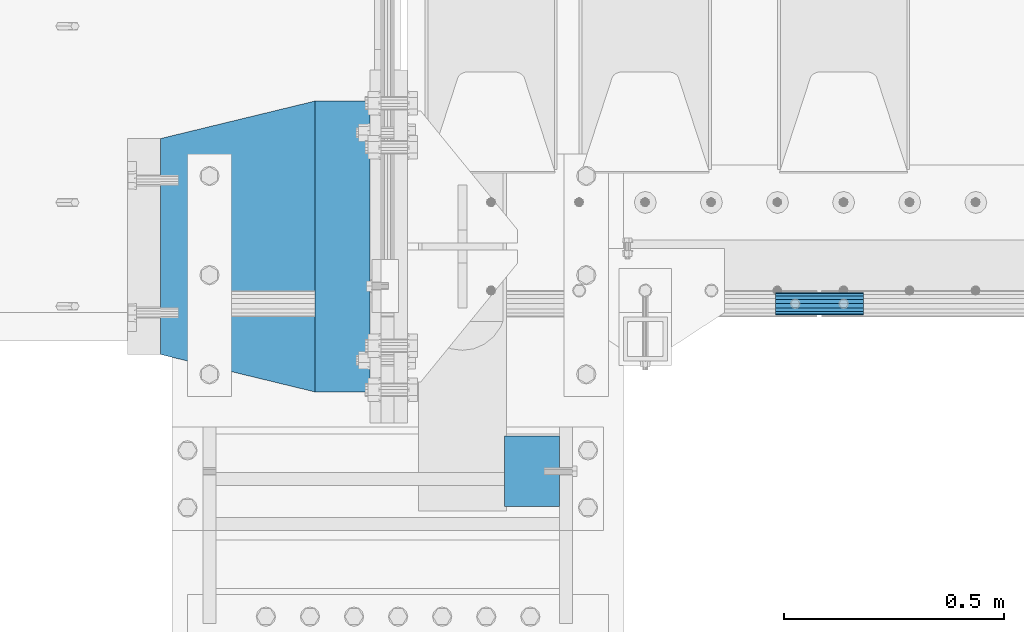
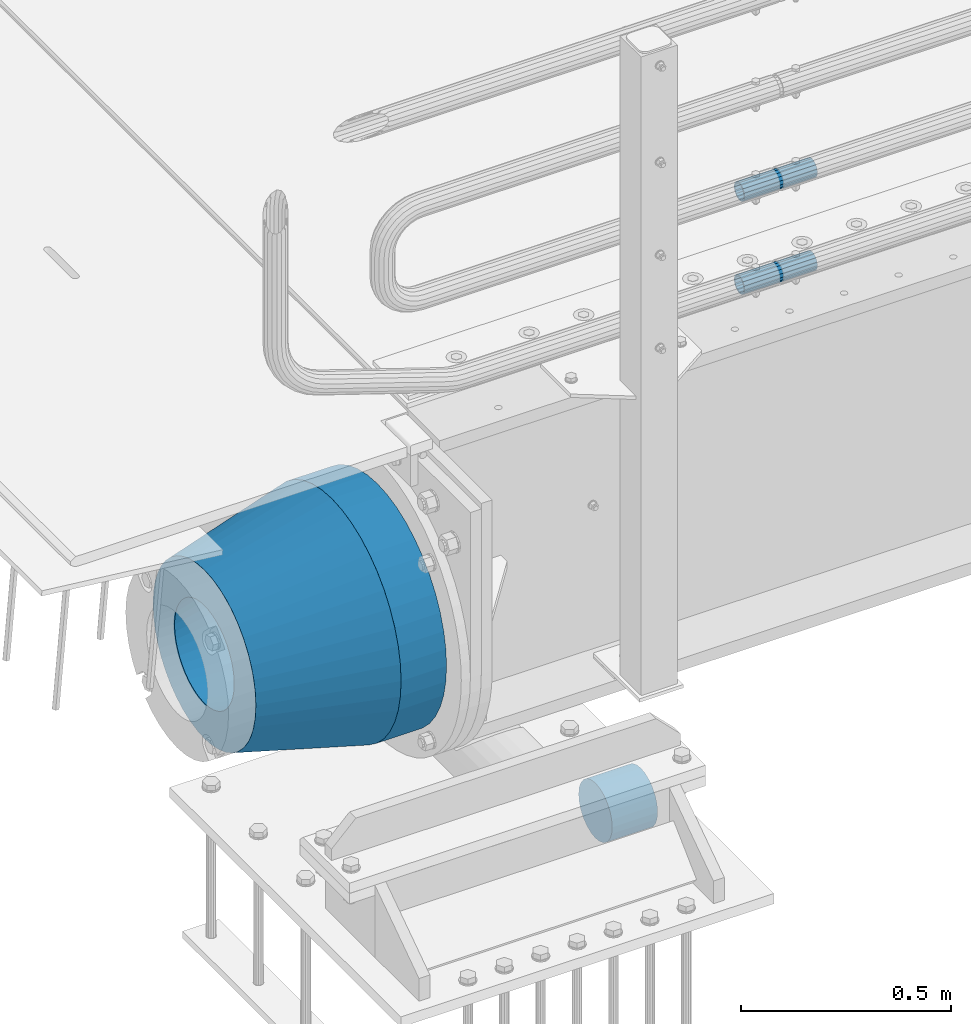
# One storey, part 151 of 270: 5 beams.
"""IFC2X3 building model written with IfcOpenShell, lengths in millimetres."""

from ifc_helpers import new_model, si_unit, frame, origin_with_axes, place, context, subcontext, project, spatial, faceted_brep, material, type_object, element, save


model = new_model("IFC2X3")

# Units and contexts
model_context = context("Model", 3, precision=1e-05, world=origin_with_axes())
body_context = subcontext(model_context, "Body", "Model", "MODEL_VIEW")
ifc_project = project(units=[si_unit("LENGTHUNIT", "METRE", prefix="MILLI"), si_unit("AREAUNIT", "SQUARE_METRE"), si_unit("VOLUMEUNIT", "CUBIC_METRE"), si_unit("MASSUNIT", "GRAM", prefix="KILO"), si_unit("TIMEUNIT", "SECOND"), si_unit("PLANEANGLEUNIT", "RADIAN"), si_unit("SOLIDANGLEUNIT", "STERADIAN"), si_unit("THERMODYNAMICTEMPERATUREUNIT", "DEGREE_CELSIUS"), si_unit("LUMINOUSINTENSITYUNIT", "LUMEN")], contexts=[model_context])

# Site, building, storey
site_placement = place(None, origin_with_axes())
site = spatial("IfcSite", under=ifc_project, at=site_placement, CompositionType="ELEMENT")
building_placement = place(site_placement, origin_with_axes())
building = spatial("IfcBuilding", under=site, at=building_placement, Name="Standard", CompositionType="ELEMENT")
storey_placement = place(building_placement, origin_with_axes())
storey = spatial("IfcBuildingStorey", under=building, at=storey_placement, Name="Undefined", CompositionType="ELEMENT", Elevation=0.0)

# Beams
ifc_material_1 = material()
beam_type_1 = type_object("IfcBeamType", PredefinedType="NOTDEFINED")
beam_1_placement = place(storey_placement, frame((230.000001139999, -24510.000002262, -933.000000000004), z_axis=(0.0, 0.0, -1.0), x_axis=(1.0, 0.0, 0.0)))
element("IfcBeam", 1, at=beam_1_placement, inside=storey, type_object=beam_type_1, material=ifc_material_1, context=body_context, shape_type="Brep", body=[
    faceted_brep([(0.0, -80.0, 0.0), (2.8421709430404e-14, -77.2740661031257, -20.7055236082017), (125.0, -77.2740661031257, -20.7055236082017), (125.0, -80.0, 0.0), (0.0, -69.2820323027554, -40.0), (125.0, -69.2820323027554, -40.0), (0.0, -56.5685424949243, -56.5685424949238), (125.0, -56.5685424949243, -56.5685424949238), (0.0, -40.0, -69.2820323027552), (125.0, -40.0, -69.2820323027552), (2.8421709430404e-14, -20.7055236082015, -77.2740661031255), (125.0, -20.7055236082015, -77.2740661031255), (0.0, 0.0, -80.0), (125.0, 0.0, -80.0), (0.0, 20.7055236082015, -77.2740661031255), (125.0, 20.7055236082015, -77.2740661031255), (0.0, 40.0, -69.2820323027551), (125.0, 40.0, -69.2820323027551), (0.0, 56.5685424949243, -56.5685424949238), (125.0, 56.5685424949243, -56.5685424949238), (0.0, 69.2820323027554, -40.0), (125.0, 69.2820323027554, -40.0), (0.0, 77.2740661031257, -20.7055236082016), (125.0, 77.2740661031257, -20.7055236082016), (2.8421709430404e-14, 80.0, 0.0), (125.0, 80.0, 0.0), (0.0, 77.2740661031257, 20.7055236082017), (125.0, 77.2740661031257, 20.7055236082017), (0.0, 69.2820323027554, 40.0), (125.0, 69.2820323027554, 40.0), (0.0, 56.5685424949243, 56.5685424949238), (125.0, 56.5685424949243, 56.5685424949238), (0.0, 40.0, 69.2820323027551), (125.0, 40.0, 69.2820323027551), (0.0, 20.7055236082015, 77.2740661031255), (125.0, 20.7055236082015, 77.2740661031255), (0.0, 0.0, 80.0), (125.0, 0.0, 80.0), (2.8421709430404e-14, -20.7055236082015, 77.2740661031255), (125.0, -20.7055236082015, 77.2740661031255), (0.0, -40.0, 69.2820323027551), (125.0, -40.0, 69.2820323027551), (0.0, -56.5685424949243, 56.5685424949238), (125.0, -56.5685424949243, 56.5685424949238), (0.0, -69.2820323027554, 40.0), (125.0, -69.2820323027554, 40.0), (2.8421709430404e-14, -77.2740661031257, 20.7055236082017), (125.0, -77.2740661031257, 20.7055236082017)], [[[0, 1, 2, 3]], [[1, 4, 5, 2]], [[4, 6, 7, 5]], [[6, 8, 9, 7]], [[8, 10, 11, 9]], [[10, 12, 13, 11]], [[12, 14, 15, 13]], [[14, 16, 17, 15]], [[16, 18, 19, 17]], [[18, 20, 21, 19]], [[20, 22, 23, 21]], [[22, 24, 25, 23]], [[24, 26, 27, 25]], [[26, 28, 29, 27]], [[28, 30, 31, 29]], [[30, 32, 33, 31]], [[32, 34, 35, 33]], [[34, 36, 37, 35]], [[36, 38, 39, 37]], [[38, 40, 41, 39]], [[40, 42, 43, 41]], [[42, 44, 45, 43]], [[44, 46, 47, 45]], [[46, 0, 3, 47]], [[5, 7, 9, 11, 13, 15, 17, 19, 21, 23, 25, 27, 29, 31, 33, 35, 37, 39, 41, 43, 45, 47, 3, 2]], [[46, 44, 42, 40, 38, 36, 34, 32, 30, 28, 26, 24, 22, 20, 18, 16, 14, 12, 10, 8, 6, 4, 1, 0]]]),
])
ifc_material_2 = material()
beam_type_2 = type_object("IfcBeamType", PredefinedType="NOTDEFINED")
beam_2_placement = place(storey_placement, frame((844.997502999948, -24129.8499999996, 149.849999999726), z_axis=(0.0, 0.0, 1.0), x_axis=(1.0, 0.0, 0.0)))
element("IfcBeam", 2, at=beam_2_placement, inside=storey, type_object=beam_type_2, material=ifc_material_2, context=body_context, shape_type="Brep", body=[
    faceted_brep([(0.0, -21.8999999999996, 0.0), (0.0, -20.232961761998, 8.38076716879547), (200.0, -20.232961761998, 8.38076716879547), (200.0, -21.8999999999996, 0.0), (0.0, -15.4856385079856, 15.4856385079854), (200.0, -15.4856385079856, 15.4856385079854), (0.0, -8.3807671687955, 20.2329617619972), (200.0, -8.3807671687955, 20.2329617619972), (0.0, 0.0, 21.9), (200.0, 0.0, 21.9), (0.0, 8.3807671687955, 20.2329617619972), (200.0, 8.3807671687955, 20.2329617619972), (0.0, 15.4856385079856, 15.4856385079854), (200.0, 15.4856385079856, 15.4856385079854), (0.0, 20.232961761998, 8.38076716879547), (200.0, 20.232961761998, 8.38076716879547), (0.0, 21.8999999999996, 0.0), (200.0, 21.8999999999996, 0.0), (0.0, 20.232961761998, -8.38076716879547), (200.0, 20.232961761998, -8.38076716879547), (0.0, 15.4856385079856, -15.4856385079854), (200.0, 15.4856385079856, -15.4856385079854), (0.0, 8.3807671687955, -20.2329617619972), (200.0, 8.3807671687955, -20.2329617619972), (0.0, 0.0, -21.9), (200.0, 0.0, -21.9), (0.0, -8.3807671687955, -20.2329617619972), (200.0, -8.3807671687955, -20.2329617619972), (0.0, -15.4856385079856, -15.4856385079854), (200.0, -15.4856385079856, -15.4856385079854), (0.0, -20.232961761998, -8.38076716879547), (200.0, -20.232961761998, -8.38076716879547), (0.0, -25.5, 0.0), (0.0, -23.5589280790373, -9.7584275253098), (200.0, -23.5589280790373, -9.7584275253098), (200.0, -25.5, 0.0), (0.0, -18.0312229202573, -18.031222920257), (200.0, -18.0312229202573, -18.031222920257), (0.0, -9.75842752531025, -23.5589280790378), (200.0, -9.75842752531025, -23.5589280790378), (0.0, 0.0, -25.5), (200.0, 0.0, -25.5), (0.0, 9.75842752531025, -23.5589280790378), (200.0, 9.75842752531025, -23.5589280790378), (0.0, 18.0312229202573, -18.031222920257), (200.0, 18.0312229202573, -18.031222920257), (0.0, 23.5589280790373, -9.7584275253098), (200.0, 23.5589280790373, -9.7584275253098), (0.0, 25.5, 0.0), (200.0, 25.5, 0.0), (0.0, 23.5589280790373, 9.7584275253098), (200.0, 23.5589280790373, 9.7584275253098), (0.0, 18.0312229202573, 18.031222920257), (200.0, 18.0312229202573, 18.031222920257), (0.0, 9.75842752531025, 23.5589280790378), (200.0, 9.75842752531025, 23.5589280790378), (0.0, 0.0, 25.5), (200.0, 0.0, 25.5), (0.0, -9.75842752531025, 23.5589280790378), (200.0, -9.75842752531025, 23.5589280790378), (0.0, -18.0312229202573, 18.031222920257), (200.0, -18.0312229202573, 18.031222920257), (0.0, -23.5589280790373, 9.7584275253098), (200.0, -23.5589280790373, 9.7584275253098)], [[[0, 1, 2, 3]], [[1, 4, 5, 2]], [[4, 6, 7, 5]], [[6, 8, 9, 7]], [[8, 10, 11, 9]], [[10, 12, 13, 11]], [[12, 14, 15, 13]], [[14, 16, 17, 15]], [[16, 18, 19, 17]], [[18, 20, 21, 19]], [[20, 22, 23, 21]], [[22, 24, 25, 23]], [[24, 26, 27, 25]], [[26, 28, 29, 27]], [[28, 30, 31, 29]], [[30, 0, 3, 31]], [[32, 33, 34, 35]], [[33, 36, 37, 34]], [[36, 38, 39, 37]], [[38, 40, 41, 39]], [[40, 42, 43, 41]], [[42, 44, 45, 43]], [[44, 46, 47, 45]], [[46, 48, 49, 47]], [[48, 50, 51, 49]], [[50, 52, 53, 51]], [[52, 54, 55, 53]], [[54, 56, 57, 55]], [[56, 58, 59, 57]], [[58, 60, 61, 59]], [[60, 62, 63, 61]], [[62, 32, 35, 63]], [[37, 39, 41, 43, 45, 47, 49, 51, 53, 55, 57, 59, 61, 63, 35, 34], [5, 7, 9, 11, 13, 15, 17, 19, 21, 23, 25, 27, 29, 31, 3, 2]], [[62, 60, 58, 56, 54, 52, 50, 48, 46, 44, 42, 40, 38, 36, 33, 32], [30, 28, 26, 24, 22, 20, 18, 16, 14, 12, 10, 8, 6, 4, 1, 0]]]),
])
beam_3_placement = place(storey_placement, frame((844.997502999948, -24129.8499999996, 420.149999999725), z_axis=(0.0, 0.0, 1.0), x_axis=(1.0, 0.0, 0.0)))
element("IfcBeam", 3, at=beam_3_placement, inside=storey, type_object=beam_type_2, material=ifc_material_2, context=body_context, shape_type="Brep", body=[
    faceted_brep([(0.0, -21.8999999999996, 0.0), (0.0, -20.232961761998, 8.38076716879547), (200.0, -20.232961761998, 8.38076716879547), (200.0, -21.8999999999996, 0.0), (0.0, -15.4856385079856, 15.4856385079854), (200.0, -15.4856385079856, 15.4856385079854), (0.0, -8.3807671687955, 20.2329617619972), (200.0, -8.3807671687955, 20.2329617619972), (0.0, 0.0, 21.9), (200.0, 0.0, 21.9), (0.0, 8.3807671687955, 20.2329617619972), (200.0, 8.3807671687955, 20.2329617619972), (0.0, 15.4856385079856, 15.4856385079854), (200.0, 15.4856385079856, 15.4856385079854), (0.0, 20.232961761998, 8.38076716879547), (200.0, 20.232961761998, 8.38076716879547), (0.0, 21.8999999999996, 0.0), (200.0, 21.8999999999996, 0.0), (0.0, 20.232961761998, -8.38076716879547), (200.0, 20.232961761998, -8.38076716879547), (0.0, 15.4856385079856, -15.4856385079854), (200.0, 15.4856385079856, -15.4856385079854), (0.0, 8.3807671687955, -20.2329617619972), (200.0, 8.3807671687955, -20.2329617619972), (0.0, 0.0, -21.9), (200.0, 0.0, -21.9), (0.0, -8.3807671687955, -20.2329617619972), (200.0, -8.3807671687955, -20.2329617619972), (0.0, -15.4856385079856, -15.4856385079854), (200.0, -15.4856385079856, -15.4856385079854), (0.0, -20.232961761998, -8.38076716879547), (200.0, -20.232961761998, -8.38076716879547), (0.0, -25.5, 0.0), (0.0, -23.5589280790373, -9.7584275253098), (200.0, -23.5589280790373, -9.7584275253098), (200.0, -25.5, 0.0), (0.0, -18.0312229202573, -18.031222920257), (200.0, -18.0312229202573, -18.031222920257), (0.0, -9.75842752531025, -23.5589280790378), (200.0, -9.75842752531025, -23.5589280790378), (0.0, 0.0, -25.5), (200.0, 0.0, -25.5), (0.0, 9.75842752531025, -23.5589280790378), (200.0, 9.75842752531025, -23.5589280790378), (0.0, 18.0312229202573, -18.031222920257), (200.0, 18.0312229202573, -18.031222920257), (0.0, 23.5589280790373, -9.7584275253098), (200.0, 23.5589280790373, -9.7584275253098), (0.0, 25.5, 0.0), (200.0, 25.5, 0.0), (0.0, 23.5589280790373, 9.7584275253098), (200.0, 23.5589280790373, 9.7584275253098), (0.0, 18.0312229202573, 18.031222920257), (200.0, 18.0312229202573, 18.031222920257), (0.0, 9.75842752531025, 23.5589280790378), (200.0, 9.75842752531025, 23.5589280790378), (0.0, 0.0, 25.5), (200.0, 0.0, 25.5), (0.0, -9.75842752531025, 23.5589280790378), (200.0, -9.75842752531025, 23.5589280790378), (0.0, -18.0312229202573, 18.031222920257), (200.0, -18.0312229202573, 18.031222920257), (0.0, -23.5589280790373, 9.7584275253098), (200.0, -23.5589280790373, 9.7584275253098)], [[[0, 1, 2, 3]], [[1, 4, 5, 2]], [[4, 6, 7, 5]], [[6, 8, 9, 7]], [[8, 10, 11, 9]], [[10, 12, 13, 11]], [[12, 14, 15, 13]], [[14, 16, 17, 15]], [[16, 18, 19, 17]], [[18, 20, 21, 19]], [[20, 22, 23, 21]], [[22, 24, 25, 23]], [[24, 26, 27, 25]], [[26, 28, 29, 27]], [[28, 30, 31, 29]], [[30, 0, 3, 31]], [[32, 33, 34, 35]], [[33, 36, 37, 34]], [[36, 38, 39, 37]], [[38, 40, 41, 39]], [[40, 42, 43, 41]], [[42, 44, 45, 43]], [[44, 46, 47, 45]], [[46, 48, 49, 47]], [[48, 50, 51, 49]], [[50, 52, 53, 51]], [[52, 54, 55, 53]], [[54, 56, 57, 55]], [[56, 58, 59, 57]], [[58, 60, 61, 59]], [[60, 62, 63, 61]], [[62, 32, 35, 63]], [[37, 39, 41, 43, 45, 47, 49, 51, 53, 55, 57, 59, 61, 63, 35, 34], [5, 7, 9, 11, 13, 15, 17, 19, 21, 23, 25, 27, 29, 31, 3, 2]], [[62, 60, 58, 56, 54, 52, 50, 48, 46, 44, 42, 40, 38, 36, 33, 32], [30, 28, 26, 24, 22, 20, 18, 16, 14, 12, 10, 8, 6, 4, 1, 0]]]),
])
ifc_material_3 = material(Name="STEEL/S355N")
beam_type_3 = type_object("IfcBeamType", PredefinedType="NOTDEFINED")
beam_4_placement = place(storey_placement, frame((-74.999999999991, -24000.0, -515.0), z_axis=(0.0, 0.0, 1.0), x_axis=(-1.0, 0.0, 0.0)))
element("IfcBeam", 4, at=beam_4_placement, inside=storey, type_object=beam_type_3, material=ifc_material_3, context=body_context, shape_type="Brep", body=[
    faceted_brep([(0.0, -215.0, 0.0), (0.0, -212.811610004401, 30.5976902287563), (125.0, -212.811610004401, 30.5976902287563), (125.0, -215.0, 0.0), (0.0, -206.290989327117, 60.5724997209074), (125.0, -206.290989327117, 60.5724997209074), (0.0, -195.570879001221, 89.3142277954056), (125.0, -195.570879001221, 89.3142277954056), (0.0, -180.869509558705, 116.237775752953), (125.0, -180.869509558705, 116.237775752953), (0.0, -162.486158486165, 140.795057798236), (125.0, -162.486158486165, 140.795057798236), (0.0, -140.795057798236, 162.486158486165), (125.0, -140.795057798236, 162.486158486165), (0.0, -116.237775752954, 180.869509558704), (125.0, -116.237775752954, 180.869509558704), (0.0, -89.3142277954048, 195.570879001222), (125.0, -89.3142277954048, 195.570879001222), (0.0, -60.5724997209072, 206.290989327117), (125.0, -60.5724997209072, 206.290989327117), (0.0, -30.5976902287566, 212.811610004401), (125.0, -30.5976902287566, 212.811610004401), (0.0, 0.0, 215.0), (125.0, 0.0, 215.0), (0.0, 30.5976902287566, 212.811610004401), (125.0, 30.5976902287566, 212.811610004401), (0.0, 60.5724997209072, 206.290989327117), (125.0, 60.5724997209072, 206.290989327117), (0.0, 89.3142277954048, 195.570879001221), (125.0, 89.3142277954048, 195.570879001221), (0.0, 116.237775752954, 180.869509558704), (125.0, 116.237775752954, 180.869509558704), (0.0, 140.795057798236, 162.486158486165), (125.0, 140.795057798236, 162.486158486165), (0.0, 162.486158486165, 140.795057798236), (125.0, 162.486158486165, 140.795057798236), (0.0, 180.869509558705, 116.237775752953), (125.0, 180.869509558705, 116.237775752953), (0.0, 195.570879001221, 89.3142277954056), (125.0, 195.570879001221, 89.3142277954056), (0.0, 206.290989327117, 60.5724997209073), (125.0, 206.290989327117, 60.5724997209073), (0.0, 212.811610004401, 30.5976902287563), (125.0, 212.811610004401, 30.5976902287563), (0.0, 215.0, 0.0), (125.0, 215.0, 0.0), (0.0, 212.811610004401, -30.5976902287563), (125.0, 212.811610004401, -30.5976902287563), (0.0, 206.290989327117, -60.5724997209073), (125.0, 206.290989327117, -60.5724997209073), (0.0, 195.570879001221, -89.3142277954056), (125.0, 195.570879001221, -89.3142277954056), (0.0, 180.869509558705, -116.237775752954), (125.0, 180.869509558705, -116.237775752954), (0.0, 162.486158486165, -140.795057798236), (125.0, 162.486158486165, -140.795057798236), (0.0, 140.795057798236, -162.486158486166), (125.0, 140.795057798236, -162.486158486166), (0.0, 116.237775752954, -180.869509558704), (125.0, 116.237775752954, -180.869509558704), (0.0, 89.3142277954048, -195.570879001221), (125.0, 89.3142277954048, -195.570879001221), (0.0, 60.5724997209072, -206.290989327117), (125.0, 60.5724997209072, -206.290989327117), (0.0, 30.5976902287566, -212.811610004401), (125.0, 30.5976902287566, -212.811610004401), (0.0, 0.0, -215.0), (125.0, 0.0, -215.0), (0.0, -30.5976902287566, -212.811610004401), (125.0, -30.5976902287566, -212.811610004401), (0.0, -60.5724997209072, -206.290989327117), (125.0, -60.5724997209072, -206.290989327117), (0.0, -89.3142277954048, -195.570879001221), (125.0, -89.3142277954048, -195.570879001221), (0.0, -116.237775752954, -180.869509558704), (125.0, -116.237775752954, -180.869509558704), (0.0, -140.795057798236, -162.486158486166), (125.0, -140.795057798236, -162.486158486166), (0.0, -162.486158486165, -140.795057798236), (125.0, -162.486158486165, -140.795057798236), (0.0, -180.869509558705, -116.237775752953), (125.0, -180.869509558705, -116.237775752953), (0.0, -195.570879001221, -89.3142277954056), (125.0, -195.570879001221, -89.3142277954056), (0.0, -206.290989327117, -60.5724997209073), (125.0, -206.290989327117, -60.5724997209073), (0.0, -212.811610004401, -30.5976902287563), (125.0, -212.811610004401, -30.5976902287563), (0.0, -330.0, 0.0), (0.0, -326.641075820708, -46.9638966301842), (125.0, -326.641075820708, -46.9638966301842), (125.0, -330.0, 0.0), (0.0, -316.632681292784, -92.9717437576718), (125.0, -316.632681292784, -92.9717437576718), (0.0, -300.178558466991, -137.086954290623), (125.0, -300.178558466991, -137.086954290623), (0.0, -277.613665834289, -178.411469760347), (125.0, -277.613665834289, -178.411469760347), (0.0, -249.397359536906, -216.104042201944), (125.0, -249.397359536906, -216.104042201944), (0.0, -216.104042201943, -249.397359536905), (125.0, -216.104042201943, -249.397359536905), (0.0, -178.411469760347, -277.61366583429), (125.0, -178.411469760347, -277.61366583429), (0.0, -137.086954290622, -300.178558466991), (125.0, -137.086954290622, -300.178558466991), (0.0, -92.971743757671, -316.632681292784), (125.0, -92.971743757671, -316.632681292784), (0.0, -46.9638966301845, -326.641075820708), (125.0, -46.9638966301845, -326.641075820708), (0.0, 0.0, -330.0), (125.0, 0.0, -330.0), (0.0, 46.9638966301845, -326.641075820708), (125.0, 46.9638966301845, -326.641075820708), (0.0, 92.971743757671, -316.632681292784), (125.0, 92.971743757671, -316.632681292784), (0.0, 137.086954290622, -300.178558466991), (125.0, 137.086954290622, -300.178558466991), (0.0, 178.411469760347, -277.61366583429), (125.0, 178.411469760347, -277.61366583429), (0.0, 216.104042201943, -249.397359536905), (125.0, 216.104042201943, -249.397359536905), (0.0, 249.397359536906, -216.104042201944), (125.0, 249.397359536906, -216.104042201944), (0.0, 277.613665834289, -178.411469760347), (125.0, 277.613665834289, -178.411469760347), (0.0, 300.178558466991, -137.086954290623), (125.0, 300.178558466991, -137.086954290623), (0.0, 316.632681292784, -92.9717437576717), (125.0, 316.632681292784, -92.9717437576717), (0.0, 326.641075820708, -46.9638966301841), (125.0, 326.641075820708, -46.9638966301841), (0.0, 330.0, 0.0), (125.0, 330.0, 0.0), (0.0, 326.641075820708, 46.9638966301841), (125.0, 326.641075820708, 46.9638966301841), (0.0, 316.632681292784, 92.9717437576718), (125.0, 316.632681292784, 92.9717437576718), (0.0, 300.178558466991, 137.086954290622), (125.0, 300.178558466991, 137.086954290622), (0.0, 277.613665834289, 178.411469760347), (125.0, 277.613665834289, 178.411469760347), (0.0, 249.397359536904, 216.104042201944), (125.0, 249.397359536904, 216.104042201944), (0.0, 216.104042201943, 249.397359536905), (125.0, 216.104042201943, 249.397359536905), (0.0, 178.411469760347, 277.61366583429), (125.0, 178.411469760347, 277.61366583429), (0.0, 137.086954290622, 300.178558466991), (125.0, 137.086954290622, 300.178558466991), (0.0, 92.971743757671, 316.632681292784), (125.0, 92.971743757671, 316.632681292784), (0.0, 46.9638966301845, 326.641075820708), (125.0, 46.9638966301845, 326.641075820708), (0.0, 0.0, 330.0), (125.0, 0.0, 330.0), (0.0, -46.9638966301845, 326.641075820708), (125.0, -46.9638966301845, 326.641075820708), (0.0, -92.971743757671, 316.632681292784), (125.0, -92.971743757671, 316.632681292784), (0.0, -137.086954290622, 300.178558466991), (125.0, -137.086954290622, 300.178558466991), (0.0, -178.411469760347, 277.61366583429), (125.0, -178.411469760347, 277.61366583429), (0.0, -216.104042201943, 249.397359536905), (125.0, -216.104042201943, 249.397359536905), (0.0, -249.397359536906, 216.104042201944), (125.0, -249.397359536906, 216.104042201944), (0.0, -277.613665834289, 178.411469760347), (125.0, -277.613665834289, 178.411469760347), (0.0, -300.178558466991, 137.086954290623), (125.0, -300.178558466991, 137.086954290623), (0.0, -316.632681292784, 92.9717437576718), (125.0, -316.632681292784, 92.9717437576718), (0.0, -326.641075820708, 46.9638966301841), (125.0, -326.641075820708, 46.9638966301841)], [[[0, 1, 2, 3]], [[1, 4, 5, 2]], [[4, 6, 7, 5]], [[6, 8, 9, 7]], [[8, 10, 11, 9]], [[10, 12, 13, 11]], [[12, 14, 15, 13]], [[14, 16, 17, 15]], [[16, 18, 19, 17]], [[18, 20, 21, 19]], [[20, 22, 23, 21]], [[22, 24, 25, 23]], [[24, 26, 27, 25]], [[26, 28, 29, 27]], [[28, 30, 31, 29]], [[30, 32, 33, 31]], [[32, 34, 35, 33]], [[34, 36, 37, 35]], [[36, 38, 39, 37]], [[38, 40, 41, 39]], [[40, 42, 43, 41]], [[42, 44, 45, 43]], [[44, 46, 47, 45]], [[46, 48, 49, 47]], [[48, 50, 51, 49]], [[50, 52, 53, 51]], [[52, 54, 55, 53]], [[54, 56, 57, 55]], [[56, 58, 59, 57]], [[58, 60, 61, 59]], [[60, 62, 63, 61]], [[62, 64, 65, 63]], [[64, 66, 67, 65]], [[66, 68, 69, 67]], [[68, 70, 71, 69]], [[70, 72, 73, 71]], [[72, 74, 75, 73]], [[74, 76, 77, 75]], [[76, 78, 79, 77]], [[78, 80, 81, 79]], [[80, 82, 83, 81]], [[82, 84, 85, 83]], [[84, 86, 87, 85]], [[86, 0, 3, 87]], [[88, 89, 90, 91]], [[89, 92, 93, 90]], [[92, 94, 95, 93]], [[94, 96, 97, 95]], [[96, 98, 99, 97]], [[98, 100, 101, 99]], [[100, 102, 103, 101]], [[102, 104, 105, 103]], [[104, 106, 107, 105]], [[106, 108, 109, 107]], [[108, 110, 111, 109]], [[110, 112, 113, 111]], [[112, 114, 115, 113]], [[114, 116, 117, 115]], [[116, 118, 119, 117]], [[118, 120, 121, 119]], [[120, 122, 123, 121]], [[122, 124, 125, 123]], [[124, 126, 127, 125]], [[126, 128, 129, 127]], [[128, 130, 131, 129]], [[130, 132, 133, 131]], [[132, 134, 135, 133]], [[134, 136, 137, 135]], [[136, 138, 139, 137]], [[138, 140, 141, 139]], [[140, 142, 143, 141]], [[142, 144, 145, 143]], [[144, 146, 147, 145]], [[146, 148, 149, 147]], [[148, 150, 151, 149]], [[150, 152, 153, 151]], [[152, 154, 155, 153]], [[154, 156, 157, 155]], [[156, 158, 159, 157]], [[158, 160, 161, 159]], [[160, 162, 163, 161]], [[162, 164, 165, 163]], [[164, 166, 167, 165]], [[166, 168, 169, 167]], [[168, 170, 171, 169]], [[170, 172, 173, 171]], [[172, 174, 175, 173]], [[174, 88, 91, 175]], [[93, 95, 97, 99, 101, 103, 105, 107, 109, 111, 113, 115, 117, 119, 121, 123, 125, 127, 129, 131, 133, 135, 137, 139, 141, 143, 145, 147, 149, 151, 153, 155, 157, 159, 161, 163, 165, 167, 169, 171, 173, 175, 91, 90], [5, 7, 9, 11, 13, 15, 17, 19, 21, 23, 25, 27, 29, 31, 33, 35, 37, 39, 41, 43, 45, 47, 49, 51, 53, 55, 57, 59, 61, 63, 65, 67, 69, 71, 73, 75, 77, 79, 81, 83, 85, 87, 3, 2]], [[174, 172, 170, 168, 166, 164, 162, 160, 158, 156, 154, 152, 150, 148, 146, 144, 142, 140, 138, 136, 134, 132, 130, 128, 126, 124, 122, 120, 118, 116, 114, 112, 110, 108, 106, 104, 102, 100, 98, 96, 94, 92, 89, 88], [86, 84, 82, 80, 78, 76, 74, 72, 70, 68, 66, 64, 62, 60, 58, 56, 54, 52, 50, 48, 46, 44, 42, 40, 38, 36, 34, 32, 30, 28, 26, 24, 22, 20, 18, 16, 14, 12, 10, 8, 6, 4, 1, 0]]]),
])
ifc_material_4 = material(Name="SCN-500-E2")
beam_type_4 = type_object("IfcBeamType", PredefinedType="NOTDEFINED")
beam_5_placement = place(storey_placement, frame((-199.999999999991, -24000.0, -515.0), z_axis=(0.0, 0.0, 1.0), x_axis=(-1.0, 0.0, 0.0)))
element("IfcBeam", 5, at=beam_5_placement, inside=storey, type_object=beam_type_4, material=ifc_material_4, context=body_context, shape_type="Brep", body=[
    faceted_brep([(0.0, -330.0, 0.0), (0.0, -326.641075820708, -46.9638966301842), (350.0, -242.506253260828, -34.8671353769549), (350.0, -245.0, 0.0), (0.0, -316.632681292784, -92.9717437576718), (350.0, -235.075778535553, -69.0244764261503), (0.0, -300.178558466991, -137.086954290623), (350.0, -222.859838861858, -101.776678185462), (0.0, -277.613665834289, -178.411469760347), (350.0, -206.10711554364, -132.457000276621), (0.0, -249.397359536906, -216.104042201944), (350.0, -185.158645716794, -160.440879816595), (0.0, -216.104042201943, -249.397359536905), (350.0, -160.440879816595, -185.158645716793), (0.0, -178.411469760347, -277.61366583429), (350.0, -132.457000276621, -206.107115543639), (0.0, -137.086954290622, -300.178558466991), (350.0, -101.776678185463, -222.859838861857), (0.0, -92.971743757671, -316.632681292784), (350.0, -69.0244764261497, -235.075778535552), (0.0, -46.9638966301845, -326.641075820708), (350.0, -34.867135376955, -242.506253260829), (0.0, 0.0, -330.0), (350.0, 0.0, -245.0), (0.0, 46.9638966301845, -326.641075820708), (350.0, 34.867135376955, -242.506253260829), (0.0, 92.971743757671, -316.632681292784), (350.0, 69.0244764261497, -235.075778535552), (0.0, 137.086954290622, -300.178558466991), (350.0, 101.776678185463, -222.859838861857), (0.0, 178.411469760347, -277.61366583429), (350.0, 132.457000276621, -206.107115543639), (0.0, 216.104042201943, -249.397359536905), (350.0, 160.440879816595, -185.158645716793), (0.0, 249.397359536906, -216.104042201944), (350.0, 185.158645716794, -160.440879816595), (0.0, 277.613665834289, -178.411469760347), (350.0, 206.10711554364, -132.457000276621), (0.0, 300.178558466991, -137.086954290623), (350.0, 222.859838861858, -101.776678185462), (0.0, 316.632681292784, -92.9717437576717), (350.0, 235.075778535553, -69.0244764261502), (0.0, 326.641075820708, -46.9638966301841), (350.0, 242.506253260828, -34.8671353769548), (0.0, 330.0, 0.0), (350.0, 245.0, 0.0), (0.0, 326.641075820708, 46.9638966301841), (350.0, 242.506253260828, 34.8671353769549), (0.0, 316.632681292784, 92.9717437576718), (350.0, 235.075778535553, 69.0244764261503), (0.0, 300.178558466991, 137.086954290622), (350.0, 222.859838861858, 101.776678185462), (0.0, 277.613665834289, 178.411469760347), (350.0, 206.10711554364, 132.457000276621), (0.0, 249.397359536904, 216.104042201944), (350.0, 185.158645716794, 160.440879816595), (0.0, 216.104042201943, 249.397359536905), (350.0, 160.440879816595, 185.158645716793), (0.0, 178.411469760347, 277.61366583429), (350.0, 132.457000276621, 206.107115543639), (0.0, 137.086954290622, 300.178558466991), (350.0, 101.776678185463, 222.859838861857), (0.0, 92.971743757671, 316.632681292784), (350.0, 69.0244764261497, 235.075778535552), (0.0, 46.9638966301845, 326.641075820708), (350.0, 34.867135376955, 242.506253260829), (0.0, 0.0, 330.0), (350.0, 0.0, 245.0), (0.0, -46.9638966301845, 326.641075820708), (350.0, -34.867135376955, 242.506253260829), (0.0, -92.971743757671, 316.632681292784), (350.0, -69.0244764261497, 235.075778535552), (0.0, -137.086954290622, 300.178558466991), (350.0, -101.776678185463, 222.859838861857), (0.0, -178.411469760347, 277.61366583429), (350.0, -132.457000276621, 206.107115543639), (0.0, -216.104042201943, 249.397359536905), (350.0, -160.440879816595, 185.158645716793), (0.0, -249.397359536906, 216.104042201944), (350.0, -185.158645716794, 160.440879816595), (0.0, -277.613665834289, 178.411469760347), (350.0, -206.10711554364, 132.457000276621), (0.0, -300.178558466991, 137.086954290623), (350.0, -222.859838861858, 101.776678185462), (0.0, -316.632681292784, 92.9717437576718), (350.0, -235.075778535553, 69.0244764261503), (0.0, -326.641075820708, 46.9638966301841), (350.0, -242.506253260828, 34.8671353769549), (0.0, -227.093265923131, 0.0), (0.0, -224.781783917484, 32.3187414128026), (350.0, -140.646961357605, 20.2219801595734), (350.0, -142.093265923131, 0.0), (0.0, -217.894393008413, 63.9795664499945), (350.0, -136.337490251181, 40.032299118473), (0.0, -206.571300613232, 94.3379520160985), (350.0, -129.252581008099, 59.0276759109381), (0.0, -191.043012240005, 122.775888927343), (350.0, -119.536461949354, 76.8214194436173), (0.0, -171.625639060125, 148.714462796454), (350.0, -107.386925240013, 93.0513004111044), (0.0, -148.714462796454, 171.625639060125), (350.0, -93.0513004111053, 107.386925240013), (0.0, -122.775888927343, 191.043012240005), (350.0, -76.8214194436168, 119.536461949355), (0.0, -94.3379520160979, 206.571300613232), (350.0, -59.0276759109383, 129.252581008098), (0.0, -63.9795664499943, 217.894393008413), (350.0, -40.032299118473, 136.337490251181), (0.0, -32.3187414128024, 224.781783917484), (350.0, -20.2219801595729, 140.646961357605), (0.0, 0.0, 227.093265923131), (350.0, 0.0, 142.093265923131), (0.0, 32.3187414128024, 224.781783917484), (350.0, 20.2219801595729, 140.646961357605), (0.0, 63.9795664499943, 217.894393008413), (350.0, 40.032299118473, 136.337490251181), (0.0, 94.3379520160979, 206.571300613232), (350.0, 59.0276759109383, 129.252581008098), (0.0, 122.775888927343, 191.043012240005), (350.0, 76.8214194436168, 119.536461949355), (0.0, 148.714462796454, 171.625639060125), (350.0, 93.0513004111053, 107.386925240013), (0.0, 171.625639060125, 148.714462796454), (350.0, 107.386925240013, 93.0513004111044), (0.0, 191.043012240005, 122.775888927343), (350.0, 119.536461949354, 76.8214194436174), (0.0, 206.571300613232, 94.3379520160985), (350.0, 129.252581008099, 59.0276759109382), (0.0, 217.894393008413, 63.9795664499945), (350.0, 136.337490251181, 40.032299118473), (0.0, 224.781783917484, 32.3187414128025), (350.0, 140.646961357605, 20.2219801595733), (0.0, 227.093265923131, 0.0), (350.0, 142.093265923131, 0.0), (0.0, 224.781783917484, -32.3187414128026), (350.0, 140.646961357605, -20.2219801595734), (0.0, 217.894393008413, -63.9795664499945), (350.0, 136.337490251181, -40.032299118473), (0.0, 206.571300613232, -94.3379520160985), (350.0, 129.252581008099, -59.0276759109381), (0.0, 191.043012240005, -122.775888927343), (350.0, 119.536461949354, -76.8214194436174), (0.0, 171.625639060125, -148.714462796454), (350.0, 107.386925240013, -93.0513004111044), (0.0, 148.714462796454, -171.625639060125), (350.0, 93.0513004111035, -107.386925240013), (0.0, 122.775888927343, -191.043012240005), (350.0, 76.8214194436168, -119.536461949355), (0.0, 94.3379520160979, -206.571300613232), (350.0, 59.0276759109383, -129.252581008098), (0.0, 63.9795664499943, -217.894393008413), (350.0, 40.032299118473, -136.337490251181), (0.0, 32.3187414128024, -224.781783917484), (350.0, 20.2219801595729, -140.646961357605), (0.0, 0.0, -227.093265923131), (350.0, 0.0, -142.093265923131), (0.0, -32.3187414128024, -224.781783917484), (350.0, -20.2219801595729, -140.646961357605), (0.0, -63.9795664499943, -217.894393008413), (350.0, -40.032299118473, -136.337490251181), (0.0, -94.3379520160979, -206.571300613232), (350.0, -59.0276759109383, -129.252581008098), (0.0, -122.775888927343, -191.043012240005), (350.0, -76.8214194436168, -119.536461949355), (0.0, -148.714462796454, -171.625639060125), (350.0, -93.0513004111035, -107.386925240013), (0.0, -171.625639060125, -148.714462796454), (350.0, -107.386925240013, -93.0513004111044), (0.0, -191.043012240005, -122.775888927343), (350.0, -119.536461949354, -76.8214194436174), (0.0, -206.571300613232, -94.3379520160985), (350.0, -129.252581008099, -59.0276759109381), (0.0, -217.894393008413, -63.9795664499945), (350.0, -136.337490251181, -40.032299118473), (0.0, -224.781783917484, -32.3187414128026), (350.0, -140.646961357605, -20.2219801595734)], [[[0, 1, 2, 3]], [[1, 4, 5, 2]], [[4, 6, 7, 5]], [[6, 8, 9, 7]], [[8, 10, 11, 9]], [[10, 12, 13, 11]], [[12, 14, 15, 13]], [[14, 16, 17, 15]], [[16, 18, 19, 17]], [[18, 20, 21, 19]], [[20, 22, 23, 21]], [[22, 24, 25, 23]], [[24, 26, 27, 25]], [[26, 28, 29, 27]], [[28, 30, 31, 29]], [[30, 32, 33, 31]], [[32, 34, 35, 33]], [[34, 36, 37, 35]], [[36, 38, 39, 37]], [[38, 40, 41, 39]], [[40, 42, 43, 41]], [[42, 44, 45, 43]], [[44, 46, 47, 45]], [[46, 48, 49, 47]], [[48, 50, 51, 49]], [[50, 52, 53, 51]], [[52, 54, 55, 53]], [[54, 56, 57, 55]], [[56, 58, 59, 57]], [[58, 60, 61, 59]], [[60, 62, 63, 61]], [[62, 64, 65, 63]], [[64, 66, 67, 65]], [[66, 68, 69, 67]], [[68, 70, 71, 69]], [[70, 72, 73, 71]], [[72, 74, 75, 73]], [[74, 76, 77, 75]], [[76, 78, 79, 77]], [[78, 80, 81, 79]], [[80, 82, 83, 81]], [[82, 84, 85, 83]], [[84, 86, 87, 85]], [[86, 0, 3, 87]], [[88, 89, 90, 91]], [[89, 92, 93, 90]], [[92, 94, 95, 93]], [[94, 96, 97, 95]], [[96, 98, 99, 97]], [[98, 100, 101, 99]], [[100, 102, 103, 101]], [[102, 104, 105, 103]], [[104, 106, 107, 105]], [[106, 108, 109, 107]], [[108, 110, 111, 109]], [[110, 112, 113, 111]], [[112, 114, 115, 113]], [[114, 116, 117, 115]], [[116, 118, 119, 117]], [[118, 120, 121, 119]], [[120, 122, 123, 121]], [[122, 124, 125, 123]], [[124, 126, 127, 125]], [[126, 128, 129, 127]], [[128, 130, 131, 129]], [[130, 132, 133, 131]], [[132, 134, 135, 133]], [[134, 136, 137, 135]], [[136, 138, 139, 137]], [[138, 140, 141, 139]], [[140, 142, 143, 141]], [[142, 144, 145, 143]], [[144, 146, 147, 145]], [[146, 148, 149, 147]], [[148, 150, 151, 149]], [[150, 152, 153, 151]], [[152, 154, 155, 153]], [[154, 156, 157, 155]], [[156, 158, 159, 157]], [[158, 160, 161, 159]], [[160, 162, 163, 161]], [[162, 164, 165, 163]], [[164, 166, 167, 165]], [[166, 168, 169, 167]], [[168, 170, 171, 169]], [[170, 172, 173, 171]], [[172, 174, 175, 173]], [[174, 88, 91, 175]], [[5, 7, 9, 11, 13, 15, 17, 19, 21, 23, 25, 27, 29, 31, 33, 35, 37, 39, 41, 43, 45, 47, 49, 51, 53, 55, 57, 59, 61, 63, 65, 67, 69, 71, 73, 75, 77, 79, 81, 83, 85, 87, 3, 2], [93, 95, 97, 99, 101, 103, 105, 107, 109, 111, 113, 115, 117, 119, 121, 123, 125, 127, 129, 131, 133, 135, 137, 139, 141, 143, 145, 147, 149, 151, 153, 155, 157, 159, 161, 163, 165, 167, 169, 171, 173, 175, 91, 90]], [[86, 84, 82, 80, 78, 76, 74, 72, 70, 68, 66, 64, 62, 60, 58, 56, 54, 52, 50, 48, 46, 44, 42, 40, 38, 36, 34, 32, 30, 28, 26, 24, 22, 20, 18, 16, 14, 12, 10, 8, 6, 4, 1, 0], [174, 172, 170, 168, 166, 164, 162, 160, 158, 156, 154, 152, 150, 148, 146, 144, 142, 140, 138, 136, 134, 132, 130, 128, 126, 124, 122, 120, 118, 116, 114, 112, 110, 108, 106, 104, 102, 100, 98, 96, 94, 92, 89, 88]]]),
])

save(model, "model.ifc")
